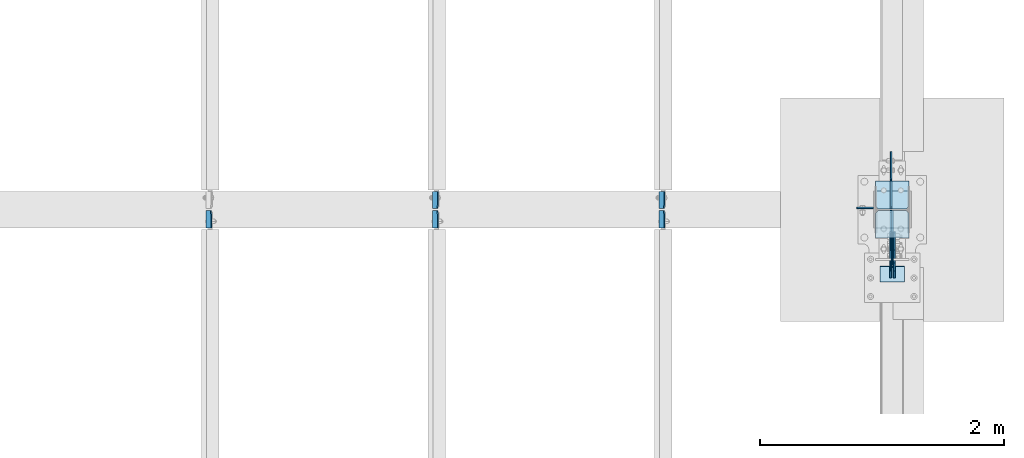
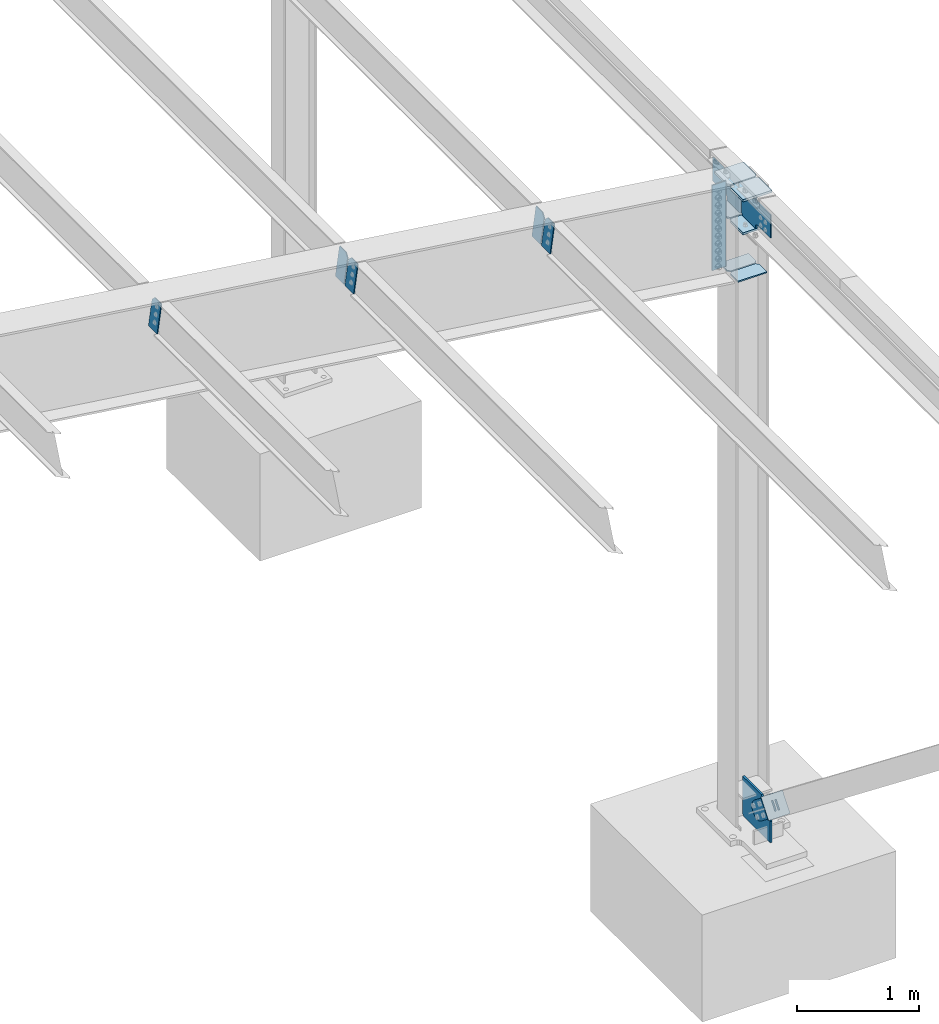
# One storey, part 1055 of 1179: 18 plates, 5 elements without a shape of their own.
"""IFC2X3 building model written with IfcOpenShell, lengths in millimetres."""

from ifc_helpers import new_model, si_unit, frame, origin_with_axes, place, context, subcontext, project, spatial, faceted_brep, material, type_object, element, aggregate, save


model = new_model("IFC2X3")

# Units and contexts
model_context = context("Model", 3, precision=1e-05, world=origin_with_axes())
body_context = subcontext(model_context, "Body", "Model", "MODEL_VIEW")
ifc_project = project(units=[si_unit("LENGTHUNIT", "METRE", prefix="MILLI"), si_unit("AREAUNIT", "SQUARE_METRE"), si_unit("VOLUMEUNIT", "CUBIC_METRE"), si_unit("MASSUNIT", "GRAM", prefix="KILO"), si_unit("TIMEUNIT", "SECOND"), si_unit("PLANEANGLEUNIT", "RADIAN"), si_unit("SOLIDANGLEUNIT", "STERADIAN"), si_unit("THERMODYNAMICTEMPERATUREUNIT", "DEGREE_CELSIUS"), si_unit("LUMINOUSINTENSITYUNIT", "LUMEN")], contexts=[model_context])

# Site, building, storey
site_placement = place(None, origin_with_axes())
site = spatial("IfcSite", under=ifc_project, at=site_placement, CompositionType="ELEMENT")
building_placement = place(site_placement, origin_with_axes())
building = spatial("IfcBuilding", under=site, at=building_placement, Name="Undefined", CompositionType="ELEMENT")
storey_placement = place(building_placement, origin_with_axes())
storey = spatial("IfcBuildingStorey", under=building, at=storey_placement, Name="Undefined", CompositionType="ELEMENT", Elevation=0.0)

# Assembly, plates
assembly_1_placement = place(storey_placement, origin_with_axes())
assembly_1 = element("IfcElementAssembly", 1, at=assembly_1_placement, inside=storey, Name="BEAM", AssemblyPlace="NOTDEFINED", PredefinedType="RIGID_FRAME")
ifc_material_1 = material(Name="STEEL/A36")
plate_type_1 = type_object("IfcPlateType", PredefinedType="NOTDEFINED")
plate_1_placement = place(assembly_1_placement, frame((36209.7723149352, 27058.9375, 6408.7167576418), z_axis=(0.0, 1.0, 0.0), x_axis=(-0.133813222971046, 0.0, -0.991006569785539)))
plate_1 = element("IfcPlate", 2, at=plate_1_placement, type_object=plate_type_1, material=ifc_material_1, Name="PLATE", context=body_context, shape_type="Brep", body=[
    faceted_brep([(0.0, -4.76250000000073, 34.9249999999993), (0.0, -4.76250000001164, 141.287499999999), (-3.63797880709171e-12, 4.76249999998981, 141.287499999999), (0.0, 4.76250000000073, 34.9249999999993), (290.512500000297, -4.76249999966967, 141.287499999999), (290.512500000294, 4.76250000033906, 141.287499999999), (290.512500000297, -4.76249999966967, 0.0), (290.512500000294, 4.76250000033906, 0.0), (34.9249992370715, -4.76249999996799, 0.0), (34.9249992370678, 4.76250000003347, 0.0)], [[[0, 1, 2, 3]], [[1, 4, 5, 2]], [[4, 6, 7, 5]], [[6, 8, 9, 7]], [[8, 0, 3, 9]], [[5, 7, 9, 3, 2]], [[8, 6, 4, 1, 0]]]),
])
plate_2_placement = place(assembly_1_placement, frame((34355.5723149357, 27058.9375, 6659.08490599859), z_axis=(0.0, 1.0, 0.0), x_axis=(-0.133813222971046, 0.0, -0.991006569785539)))
plate_2 = element("IfcPlate", 3, at=plate_2_placement, type_object=plate_type_1, material=ifc_material_1, Name="PLATE", context=body_context, shape_type="Brep", body=[
    faceted_brep([(0.0, -4.76250000000073, 34.9249999999993), (0.0, -4.76250000001164, 141.287499999999), (-3.63797880709171e-12, 4.76249999998981, 141.287499999999), (0.0, 4.76250000000073, 34.9249999999993), (290.512500000297, -4.76249999966967, 141.287499999999), (290.512500000294, 4.76250000033906, 141.287499999999), (290.512500000297, -4.76249999966967, 0.0), (290.512500000294, 4.76250000033906, 0.0), (34.9249992370715, -4.76249999996799, 0.0), (34.9249992370678, 4.76250000003347, 0.0)], [[[0, 1, 2, 3]], [[1, 4, 5, 2]], [[4, 6, 7, 5]], [[6, 8, 9, 7]], [[8, 0, 3, 9]], [[5, 7, 9, 3, 2]], [[8, 6, 4, 1, 0]]]),
])
plate_3_placement = place(assembly_1_placement, frame((36209.7723149411, 27043.0625, 6408.71675688842), z_axis=(0.0, -1.0, 0.0), x_axis=(-0.133813222971046, 0.0, -0.991006569785539)))
plate_3 = element("IfcPlate", 4, at=plate_3_placement, type_object=plate_type_1, material=ifc_material_1, Name="PLATE", context=body_context, shape_type="Brep", body=[
    faceted_brep([(0.0, -4.76250000000073, 34.9249999999993), (0.0, -4.76250000001164, 141.287499999999), (-3.63797880709171e-12, 4.76249999998981, 141.287499999999), (0.0, 4.76250000000073, 34.9249999999993), (290.512500000297, -4.76249999966967, 141.287499999999), (290.512500000294, 4.76250000033906, 141.287499999999), (290.512500000297, -4.76249999966967, 0.0), (290.512500000294, 4.76250000033906, 0.0), (34.9249992370715, -4.76249999996799, 0.0), (34.9249992370678, 4.76250000003347, 0.0)], [[[0, 1, 2, 3]], [[1, 4, 5, 2]], [[4, 6, 7, 5]], [[6, 8, 9, 7]], [[8, 0, 3, 9]], [[5, 7, 9, 3, 2]], [[8, 6, 4, 1, 0]]]),
])
plate_4_placement = place(assembly_1_placement, frame((34355.5723149415, 27043.0625, 6659.08490524521), z_axis=(0.0, -1.0, 0.0), x_axis=(-0.133813222971046, 0.0, -0.991006569785539)))
plate_4 = element("IfcPlate", 5, at=plate_4_placement, type_object=plate_type_1, material=ifc_material_1, Name="PLATE", context=body_context, shape_type="Brep", body=[
    faceted_brep([(0.0, -4.76250000000073, 34.9249999999993), (0.0, -4.76250000001164, 141.287499999999), (-3.63797880709171e-12, 4.76249999998981, 141.287499999999), (0.0, 4.76250000000073, 34.9249999999993), (290.512500000297, -4.76249999966967, 141.287499999999), (290.512500000294, 4.76250000033906, 141.287499999999), (290.512500000297, -4.76249999966967, 0.0), (290.512500000294, 4.76250000033906, 0.0), (34.9249992370715, -4.76249999996799, 0.0), (34.9249992370678, 4.76250000003347, 0.0)], [[[0, 1, 2, 3]], [[1, 4, 5, 2]], [[4, 6, 7, 5]], [[6, 8, 9, 7]], [[8, 0, 3, 9]], [[5, 7, 9, 3, 2]], [[8, 6, 4, 1, 0]]]),
])
plate_5_placement = place(assembly_1_placement, frame((32501.3723149418, 27043.0625, 6909.45305360179), z_axis=(0.0, -1.0, 0.0), x_axis=(-0.133813222971046, 0.0, -0.991006569785539)))
plate_5 = element("IfcPlate", 6, at=plate_5_placement, type_object=plate_type_1, material=ifc_material_1, Name="PLATE", context=body_context, shape_type="Brep", body=[
    faceted_brep([(0.0, -4.76250000000073, 34.9249999999993), (0.0, -4.76250000001164, 141.287499999999), (-3.63797880709171e-12, 4.76249999998981, 141.287499999999), (0.0, 4.76250000000073, 34.9249999999993), (290.512500000297, -4.76249999966967, 141.287499999999), (290.512500000294, 4.76250000033906, 141.287499999999), (290.512500000297, -4.76249999966967, 0.0), (290.512500000294, 4.76250000033906, 0.0), (34.9249992370715, -4.76249999996799, 0.0), (34.9249992370678, 4.76250000003347, 0.0)], [[[0, 1, 2, 3]], [[1, 4, 5, 2]], [[4, 6, 7, 5]], [[6, 8, 9, 7]], [[8, 0, 3, 9]], [[5, 7, 9, 3, 2]], [[8, 6, 4, 1, 0]]]),
])
aggregate(assembly_1, [plate_1, plate_2, plate_3, plate_4, plate_5])

# Assembly, plate
assembly_2_placement = place(storey_placement, origin_with_axes())
assembly_2 = element("IfcElementAssembly", 7, at=assembly_2_placement, inside=storey, Name="COLUMN", AssemblyPlace="NOTDEFINED", PredefinedType="RIGID_FRAME")
ifc_material_2 = material(Name="STEEL/A572-GR.50")
plate_type_2 = type_object("IfcPlateType", PredefinedType="NOTDEFINED")
plate_6_placement = place(assembly_2_placement, frame((38074.6, 27045.44375, -228.599999999999), z_axis=(0.0, 0.0, 1.0), x_axis=(0.0, -1.0, 0.0)))
plate_6 = element("IfcPlate", 8, at=plate_6_placement, type_object=plate_type_2, material=ifc_material_2, Name="PLATE", context=body_context, shape_type="Brep", body=[
    faceted_brep([(0.0, -9.52500000000146, 19.0499992370605), (0.0, -9.52500000000146, 393.418048976154), (0.0, 9.52500000000146, 393.418048976154), (0.0, 9.52500000000146, 19.0499992370605), (307.483903883029, -9.52500000000146, 393.418048976154), (307.483903883029, 9.52500000000146, 393.418048976154), (450.70235677221, -9.52500000000146, 211.18708185742), (450.70235677221, 9.52500000000146, 211.18708185742), (450.70235677221, -9.52500000000146, 0.0), (450.70235677221, 9.52500000000146, 0.0), (19.0499992370605, -9.52500000000146, 0.0), (19.0499992370605, 9.52500000000146, 0.0)], [[[0, 1, 2, 3]], [[1, 4, 5, 2]], [[4, 6, 7, 5]], [[6, 8, 9, 7]], [[8, 10, 11, 9]], [[10, 0, 3, 11]], [[5, 7, 9, 11, 3, 2]], [[10, 8, 6, 4, 1, 0]]]),
])

assembly_3_placement = place(storey_placement, origin_with_axes())
assembly_3 = element("IfcElementAssembly", 9, at=assembly_3_placement, inside=storey, AssemblyPlace="NOTDEFINED", PredefinedType="RIGID_FRAME")
plate_type_3 = type_object("IfcPlateType", PredefinedType="NOTDEFINED")
plate_7_placement = place(assembly_3_placement, frame((38058.725, 26549.8646879964, 223.501853368135), z_axis=(0.0, -0.61792019367569, -0.786240824587351), x_axis=(0.0, 0.786240824587352, -0.617920193675689)))
plate_7 = element("IfcPlate", 10, at=plate_7_placement, type_object=plate_type_3, material=ifc_material_1, context=body_context, shape_type="Brep", body=[
    faceted_brep([(0.0, -6.34999999999854, 0.0), (-8.18545231595635e-11, -6.34999999999854, 91.5986124346418), (-8.18545231595635e-11, 6.34999999999854, 91.5986124346418), (0.0, 6.34999999999854, 0.0), (82.5500000001266, -6.34999999999854, 91.5986124347546), (82.5500000001266, 6.34999999999854, 91.5986124347546), (184.150000000493, -6.34999999999854, 136.286806217293), (184.150000000493, 6.34999999999854, 136.286806217293), (329.234985848627, -6.34999999999854, 136.286806217511), (329.234985848627, 6.34999999999854, 136.286806217511), (363.86305410257, -6.34999999999854, 129.398855183379), (363.86305410257, 6.34999999999854, 129.398855183379), (393.219312869078, -6.34999999999854, 109.783630186394), (393.219312869078, 6.34999999999854, 109.783630186394), (412.8345378661, -6.34999999999854, 80.4273714198789), (412.8345378661, 6.34999999999854, 80.4273714198789), (419.72248890029, -6.34999999999854, 45.7993092699908), (419.72248890029, 6.34999999999854, 45.7993092699908), (412.834537866132, -6.34999999999854, 11.171241015978), (412.834537866132, 6.34999999999854, 11.171241015978), (393.219312869132, -6.34999999999854, -18.1850177505985), (393.219312869132, 6.34999999999854, -18.1850177505985), (363.863054102636, -6.34999999999854, -37.8002427476786), (363.863054102636, 6.34999999999854, -37.8002427476786), (329.234988900062, -6.34999999999854, -44.6881937819198), (329.234988900062, 6.34999999999854, -44.6881937819198), (184.150000000598, -6.34999999999854, -44.6881937821345), (184.150000000598, 6.34999999999854, -44.6881937821345), (82.550000000203, -6.34999999999854, 1.2732925824821e-10), (82.550000000203, 6.34999999999854, 1.2732925824821e-10)], [[[0, 1, 2, 3]], [[1, 4, 5, 2]], [[4, 6, 7, 5]], [[6, 8, 9, 7]], [[8, 10, 11, 9]], [[10, 12, 13, 11]], [[12, 14, 15, 13]], [[14, 16, 17, 15]], [[16, 18, 19, 17]], [[18, 20, 21, 19]], [[20, 22, 23, 21]], [[22, 24, 25, 23]], [[24, 26, 27, 25]], [[26, 28, 29, 27]], [[28, 0, 3, 29]], [[5, 7, 9, 11, 13, 15, 17, 19, 21, 23, 25, 27, 29, 3, 2]], [[28, 26, 24, 22, 20, 18, 16, 14, 12, 10, 8, 6, 4, 1, 0]]]),
])
aggregate(assembly_3, [plate_7])

assembly_4_placement = place(storey_placement, origin_with_axes())
assembly_4 = element("IfcElementAssembly", 11, at=assembly_4_placement, inside=storey, AssemblyPlace="NOTDEFINED", PredefinedType="RIGID_FRAME")
plate_8_placement = place(assembly_4_placement, frame((38090.475, 26549.8646879964, 223.501853368135), z_axis=(0.0, -0.61792019367569, -0.786240824587351), x_axis=(0.0, 0.786240824587352, -0.617920193675689)))
plate_8 = element("IfcPlate", 12, at=plate_8_placement, type_object=plate_type_3, material=ifc_material_1, context=body_context, shape_type="Brep", body=[
    faceted_brep([(0.0, -6.34999999999854, 0.0), (-8.18545231595635e-11, -6.34999999999854, 91.5986124346418), (-8.18545231595635e-11, 6.34999999999854, 91.5986124346418), (0.0, 6.34999999999854, 0.0), (82.5500000001266, -6.34999999999854, 91.5986124347546), (82.5500000001266, 6.34999999999854, 91.5986124347546), (184.150000000493, -6.34999999999854, 136.286806217293), (184.150000000493, 6.34999999999854, 136.286806217293), (329.234985848627, -6.34999999999854, 136.286806217511), (329.234985848627, 6.34999999999854, 136.286806217511), (363.86305410257, -6.34999999999854, 129.398855183379), (363.86305410257, 6.34999999999854, 129.398855183379), (393.219312869078, -6.34999999999854, 109.783630186394), (393.219312869078, 6.34999999999854, 109.783630186394), (412.8345378661, -6.34999999999854, 80.4273714198789), (412.8345378661, 6.34999999999854, 80.4273714198789), (419.72248890029, -6.34999999999854, 45.7993092699908), (419.72248890029, 6.34999999999854, 45.7993092699908), (412.834537866132, -6.34999999999854, 11.171241015978), (412.834537866132, 6.34999999999854, 11.171241015978), (393.219312869132, -6.34999999999854, -18.1850177505985), (393.219312869132, 6.34999999999854, -18.1850177505985), (363.863054102636, -6.34999999999854, -37.8002427476786), (363.863054102636, 6.34999999999854, -37.8002427476786), (329.234988900062, -6.34999999999854, -44.6881937819198), (329.234988900062, 6.34999999999854, -44.6881937819198), (184.150000000598, -6.34999999999854, -44.6881937821345), (184.150000000598, 6.34999999999854, -44.6881937821345), (82.550000000203, -6.34999999999854, 1.2732925824821e-10), (82.550000000203, 6.34999999999854, 1.2732925824821e-10)], [[[0, 1, 2, 3]], [[1, 4, 5, 2]], [[4, 6, 7, 5]], [[6, 8, 9, 7]], [[8, 10, 11, 9]], [[10, 12, 13, 11]], [[12, 14, 15, 13]], [[14, 16, 17, 15]], [[16, 18, 19, 17]], [[18, 20, 21, 19]], [[20, 22, 23, 21]], [[22, 24, 25, 23]], [[24, 26, 27, 25]], [[26, 28, 29, 27]], [[28, 0, 3, 29]], [[5, 7, 9, 11, 13, 15, 17, 19, 21, 23, 25, 27, 29, 3, 2]], [[28, 26, 24, 22, 20, 18, 16, 14, 12, 10, 8, 6, 4, 1, 0]]]),
])
aggregate(assembly_4, [plate_8])

assembly_5_placement = place(storey_placement, origin_with_axes())
assembly_5 = element("IfcElementAssembly", 13, at=assembly_5_placement, inside=storey, Name="Plate", AssemblyPlace="NOTDEFINED", PredefinedType="RIGID_FRAME")
plate_type_4 = type_object("IfcPlateType", PredefinedType="NOTDEFINED")
plate_9_placement = place(assembly_5_placement, frame((37973.0, 26461.2799947716, 105.648604689442), z_axis=(0.0, 0.617920193675691, 0.786240824587351), x_axis=(1.0, 0.0, 0.0)))
plate_9 = element("IfcPlate", 14, at=plate_9_placement, type_object=plate_type_4, material=ifc_material_1, Name="Plate", context=body_context, shape_type="Brep", body=[
    faceted_brep([(0.0, -3.17500000000109, 0.0), (0.0, -3.17500000000291, 203.200000000368), (0.0, 3.17499999998836, 203.200000000361), (0.0, 3.17500000000109, 7.27595761418343e-12), (203.199999999997, -3.17500000000291, 203.200000000368), (203.199999999997, 3.17499999998836, 203.200000000361), (203.199999999997, -3.17499999999927, 3.63797880709171e-12), (203.199999999997, 3.17499999999382, -3.63797880709171e-12)], [[[0, 1, 2, 3]], [[1, 4, 5, 2]], [[4, 6, 7, 5]], [[6, 0, 3, 7]], [[5, 7, 3, 2]], [[6, 4, 1, 0]]]),
])
aggregate(assembly_5, [plate_9])

# Plate
plate_type_5 = type_object("IfcPlateType", PredefinedType="NOTDEFINED")
plate_10_placement = place(assembly_2_placement, frame((38211.125, 27285.15625, 5756.275), z_axis=(-1.0, 0.0, 0.0), x_axis=(0.0, -1.0, 0.0)))
plate_10 = element("IfcPlate", 15, at=plate_10_placement, type_object=plate_type_5, material=ifc_material_2, Name="PLATE", context=body_context, shape_type="Brep", body=[
    faceted_brep([(0.0, -9.52499999999964, 0.0), (0.0, -9.52499999999964, 273.050000000003), (0.0, 9.52499999999964, 273.050000000003), (0.0, 9.52499999999964, 0.0), (206.374999618529, -9.52499999999964, 273.049999999996), (206.374999618529, 9.52499999999964, 273.049999999996), (228.599999999999, -9.52499999999964, 250.824999618526), (228.599999999999, 9.52499999999964, 250.824999618526), (228.599999999999, -9.52499999999964, 22.2250003814697), (228.599999999999, 9.52499999999964, 22.2250003814697), (206.374999618529, -9.52499999999964, 0.0), (206.374999618529, 9.52499999999964, 0.0)], [[[0, 1, 2, 3]], [[1, 4, 5, 2]], [[4, 6, 7, 5]], [[6, 8, 9, 7]], [[8, 10, 11, 9]], [[10, 0, 3, 11]], [[5, 7, 9, 11, 3, 2]], [[10, 8, 6, 4, 1, 0]]]),
])

plate_11_placement = place(assembly_2_placement, frame((38211.125, 27285.15625, 6086.475), z_axis=(-1.0, 0.0, 0.0), x_axis=(0.0, -1.0, 0.0)))
plate_11 = element("IfcPlate", 16, at=plate_11_placement, type_object=plate_type_5, material=ifc_material_2, Name="PLATE", context=body_context, shape_type="Brep", body=[
    faceted_brep([(0.0, -9.52499999999964, 0.0), (0.0, -9.52499999999964, 273.050000000003), (0.0, 9.52499999999964, 273.050000000003), (0.0, 9.52499999999964, 0.0), (206.374999618529, -9.52499999999964, 273.049999999996), (206.374999618529, 9.52499999999964, 273.049999999996), (228.599999999999, -9.52499999999964, 250.824999618526), (228.599999999999, 9.52499999999964, 250.824999618526), (228.599999999999, -9.52499999999964, 22.2250003814697), (228.599999999999, 9.52499999999964, 22.2250003814697), (206.374999618529, -9.52499999999964, 0.0), (206.374999618529, 9.52499999999964, 0.0)], [[[0, 1, 2, 3]], [[1, 4, 5, 2]], [[4, 6, 7, 5]], [[6, 8, 9, 7]], [[8, 10, 11, 9]], [[10, 0, 3, 11]], [[5, 7, 9, 11, 3, 2]], [[10, 8, 6, 4, 1, 0]]]),
])

plate_type_6 = type_object("IfcPlateType", PredefinedType="NOTDEFINED")
plate_12_placement = place(assembly_2_placement, frame((38064.28125, 27056.5484025688, 5784.85), z_axis=(0.0, 0.707106781186542, 0.707106781186553), x_axis=(0.0, 0.707106781186553, -0.707106781186542)))
plate_12 = element("IfcPlate", 17, at=plate_12_placement, type_object=plate_type_6, material=ifc_material_2, Name="PLATE", context=body_context, shape_type="Brep", body=[
    faceted_brep([(0.0, -6.34999999999854, 0.0), (-193.075506603058, -6.34999999999854, 193.075506603045), (-193.075506603058, 6.34999999999854, 193.075506603045), (0.0, 6.34999999999854, 0.0), (-193.075506603127, -6.34999999999854, 220.016274966196), (-193.075506603127, 6.34999999999854, 220.016274966196), (-45.4625466137659, -6.34999999999854, 367.629234955561), (-45.4625466137659, 6.34999999999854, 367.629234955561), (-40.9724182834834, -6.34999999999854, 363.139106625282), (-40.9724182834834, 6.34999999999854, 363.139106625282), (-32.7320653471797, -6.34999999999854, 357.633078824321), (-32.7320653471797, 6.34999999999854, 357.633078824321), (-23.0119063110942, -6.34999999999854, 355.699618979137), (-23.0119063110942, 6.34999999999854, 355.699618979137), (-13.2917472750196, -6.34999999999854, 357.633078824298), (-13.2917472750196, 6.34999999999854, 357.633078824298), (-5.05139433873046, -6.34999999999854, 363.139106625236), (-5.05139433873046, 6.34999999999854, 363.139106625236), (147.612959988404, -6.34999999999854, 515.803460952378), (147.612959988404, 6.34999999999854, 515.803460952378), (309.257570167709, -6.34999999999854, 354.158850773083), (309.257570167709, 6.34999999999854, 354.158850773083), (156.593215840574, -6.34999999999854, 201.494496445941), (156.593215840574, 6.34999999999854, 201.494496445941), (151.087188039633, -6.34999999999854, 193.254143509652), (151.087188039633, 6.34999999999854, 193.254143509652), (149.153728194477, -6.34999999999854, 183.533984473575), (149.153728194477, 6.34999999999854, 183.533984473575), (151.087188039659, -6.34999999999854, 173.813825437492), (151.087188039659, 6.34999999999854, 173.813825437492), (156.593215840621, -6.34999999999854, 165.573472501186), (156.593215840621, 6.34999999999854, 165.573472501186), (174.553728352508, -6.34999999999854, 147.612959989299), (174.553728352508, 6.34999999999854, 147.612959989299), (26.9407683631471, -6.34999999999854, -6.91215973347425e-11), (26.9407683631471, 6.34999999999854, -6.91215973347425e-11)], [[[0, 1, 2, 3]], [[1, 4, 5, 2]], [[4, 6, 7, 5]], [[6, 8, 9, 7]], [[8, 10, 11, 9]], [[10, 12, 13, 11]], [[12, 14, 15, 13]], [[14, 16, 17, 15]], [[16, 18, 19, 17]], [[18, 20, 21, 19]], [[20, 22, 23, 21]], [[22, 24, 25, 23]], [[24, 26, 27, 25]], [[26, 28, 29, 27]], [[28, 30, 31, 29]], [[30, 32, 33, 31]], [[32, 34, 35, 33]], [[34, 0, 3, 35]], [[5, 7, 9, 11, 13, 15, 17, 19, 21, 23, 25, 27, 29, 31, 33, 35, 3, 2]], [[34, 32, 30, 28, 26, 24, 22, 20, 18, 16, 14, 12, 10, 8, 6, 4, 1, 0]]]),
])

plate_type_7 = type_object("IfcPlateType", PredefinedType="NOTDEFINED")
plate_13_placement = place(assembly_2_placement, frame((37938.075, 26816.84375, 5754.6875), z_axis=(1.0, 0.0, 0.0), x_axis=(0.0, 1.0, 0.0)))
plate_13 = element("IfcPlate", 18, at=plate_13_placement, type_object=plate_type_7, material=ifc_material_2, Name="PLATE", context=body_context, shape_type="Brep", body=[
    faceted_brep([(0.0, -11.1125000000002, 0.0), (0.0, -11.1125000000002, 273.050000000003), (0.0, 11.1125000000002, 273.050000000003), (0.0, 11.1125000000002, 0.0), (206.374999618529, -11.1125000000002, 273.050000000003), (206.374999618529, 11.1125000000002, 273.050000000003), (228.599999999999, -11.1125000000002, 250.824999618533), (228.599999999999, 11.1125000000002, 250.824999618533), (228.599999999999, -11.1125000000002, 22.2250003814697), (228.599999999999, 11.1125000000002, 22.2250003814697), (206.374999618529, -11.1125000000002, 0.0), (206.374999618529, 11.1125000000002, 0.0)], [[[0, 1, 2, 3]], [[1, 4, 5, 2]], [[4, 6, 7, 5]], [[6, 8, 9, 7]], [[8, 10, 11, 9]], [[10, 0, 3, 11]], [[5, 7, 9, 11, 3, 2]], [[10, 8, 6, 4, 1, 0]]]),
])

plate_14_placement = place(assembly_2_placement, frame((37938.075, 26816.84375, 6084.8875), z_axis=(1.0, 0.0, 0.0), x_axis=(0.0, 1.0, 0.0)))
plate_14 = element("IfcPlate", 19, at=plate_14_placement, type_object=plate_type_7, material=ifc_material_2, Name="PLATE", context=body_context, shape_type="Brep", body=[
    faceted_brep([(0.0, -11.1125000000002, 0.0), (0.0, -11.1125000000002, 273.050000000003), (0.0, 11.1125000000002, 273.050000000003), (0.0, 11.1125000000002, 0.0), (206.374999618529, -11.1125000000002, 273.050000000003), (206.374999618529, 11.1125000000002, 273.050000000003), (228.599999999999, -11.1125000000002, 250.824999618533), (228.599999999999, 11.1125000000002, 250.824999618533), (228.599999999999, -11.1125000000002, 22.2250003814697), (228.599999999999, 11.1125000000002, 22.2250003814697), (206.374999618529, -11.1125000000002, 0.0), (206.374999618529, 11.1125000000002, 0.0)], [[[0, 1, 2, 3]], [[1, 4, 5, 2]], [[4, 6, 7, 5]], [[6, 8, 9, 7]], [[8, 10, 11, 9]], [[10, 0, 3, 11]], [[5, 7, 9, 11, 3, 2]], [[10, 8, 6, 4, 1, 0]]]),
])

plate_type_8 = type_object("IfcPlateType", PredefinedType="NOTDEFINED")
plate_15_placement = place(assembly_2_placement, frame((38063.4875, 27045.44375, 5784.85000339458), z_axis=(0.0, -0.707106781186506, 0.707106781186589), x_axis=(0.0, -0.70710678118659, -0.707106781186505)))
plate_15 = element("IfcPlate", 20, at=plate_15_placement, type_object=plate_type_8, material=ifc_material_2, Name="PLATE", context=body_context, shape_type="Brep", body=[
    faceted_brep([(0.0, -6.34999999999854, 0.0), (-190.8304439942, -6.34999999999854, 190.830441150882), (-190.8304439942, 6.34999999999854, 190.830441150882), (0.0, 6.34999999999854, 0.0), (-190.830443994197, -6.34999999999854, 217.771209313387), (-190.830443994197, 6.34999999999854, 217.771209313387), (-43.2174837074454, -6.34999999999854, 365.384167401086), (-43.2174837074454, 6.34999999999854, 365.384167401086), (-40.9724182834834, -6.34999999999854, 363.139106625282), (-40.9724182834834, 6.34999999999854, 363.139106625282), (-32.7320653471797, -6.34999999999854, 357.633078824321), (-32.7320653471797, 6.34999999999854, 357.633078824321), (-23.0119063110942, -6.34999999999854, 355.699618979137), (-23.0119063110942, 6.34999999999854, 355.699618979137), (-13.2917472750196, -6.34999999999854, 357.633078824298), (-13.2917472750196, 6.34999999999854, 357.633078824298), (-5.05139433873046, -6.34999999999854, 363.139106625236), (-5.05139433873046, 6.34999999999854, 363.139106625236), (147.612959988404, -6.34999999999854, 515.803460952378), (147.612959988404, 6.34999999999854, 515.803460952378), (309.257570167709, -6.34999999999854, 354.158850773083), (309.257570167709, 6.34999999999854, 354.158850773083), (156.593215840574, -6.34999999999854, 201.494496445941), (156.593215840574, 6.34999999999854, 201.494496445941), (151.087188039633, -6.34999999999854, 193.254143509652), (151.087188039633, 6.34999999999854, 193.254143509652), (149.153728194477, -6.34999999999854, 183.533984473575), (149.153728194477, 6.34999999999854, 183.533984473575), (151.087188039659, -6.34999999999854, 173.813825437492), (151.087188039659, 6.34999999999854, 173.813825437492), (156.593215840621, -6.34999999999854, 165.573472501186), (156.593215840621, 6.34999999999854, 165.573472501186), (174.553728352508, -6.34999999999854, 147.612959989299), (174.553728352508, 6.34999999999854, 147.612959989299), (26.9407683631471, -6.34999999999854, -6.91215973347425e-11), (26.9407683631471, 6.34999999999854, -6.91215973347425e-11)], [[[0, 1, 2, 3]], [[1, 4, 5, 2]], [[4, 6, 7, 5]], [[6, 8, 9, 7]], [[8, 10, 11, 9]], [[10, 12, 13, 11]], [[12, 14, 15, 13]], [[14, 16, 17, 15]], [[16, 18, 19, 17]], [[18, 20, 21, 19]], [[20, 22, 23, 21]], [[22, 24, 25, 23]], [[24, 26, 27, 25]], [[26, 28, 29, 27]], [[28, 30, 31, 29]], [[30, 32, 33, 31]], [[32, 34, 35, 33]], [[34, 0, 3, 35]], [[5, 7, 9, 11, 13, 15, 17, 19, 21, 23, 25, 27, 29, 31, 33, 35, 3, 2]], [[34, 32, 30, 28, 26, 24, 22, 20, 18, 16, 14, 12, 10, 8, 6, 4, 1, 0]]]),
])

plate_type_9 = type_object("IfcPlateType", PredefinedType="NOTDEFINED")
plate_16_placement = place(assembly_2_placement, frame((38211.125, 27045.44375, 5226.44326994722), z_axis=(-1.0, 0.0, 0.0), x_axis=(0.0, -1.0, 0.0)))
plate_16 = element("IfcPlate", 21, at=plate_16_placement, type_object=plate_type_9, material=ifc_material_1, Name="PLATE", context=body_context, shape_type="Brep", body=[
    faceted_brep([(0.0, -6.34999999999854, 22.2250003814697), (0.0, -6.35000000000036, 250.82499961853), (0.0, 6.35000000000036, 250.82499961853), (0.0, 6.34999999999854, 22.2250003814697), (22.2250003814697, -6.35000000000036, 273.05), (22.2250003814697, 6.35000000000036, 273.05), (146.050003051758, -6.35000000000036, 273.049987792969), (146.050003051758, 6.35000000000036, 273.049987792969), (146.050003051758, -6.35000000000036, 0.0), (146.050003051758, 6.35000000000036, 0.0), (22.2250003814697, -6.34999999999854, 0.0), (22.2250003814697, 6.34999999999854, 0.0)], [[[0, 1, 2, 3]], [[1, 4, 5, 2]], [[4, 6, 7, 5]], [[6, 8, 9, 7]], [[8, 10, 11, 9]], [[10, 0, 3, 11]], [[5, 7, 9, 11, 3, 2]], [[10, 8, 6, 4, 1, 0]]]),
])

plate_17_placement = place(assembly_2_placement, frame((38211.125, 27202.60625, 5226.44326994722), z_axis=(-1.0, 0.0, 0.0), x_axis=(0.0, -1.0, 0.0)))
plate_17 = element("IfcPlate", 22, at=plate_17_placement, type_object=plate_type_9, material=ifc_material_1, Name="PLATE", context=body_context, shape_type="Brep", body=[
    faceted_brep([(0.0, -6.34999999999854, 0.0), (0.0, -6.34999999999991, 273.05), (0.0, 6.34999999999991, 273.05), (0.0, 6.34999999999854, 0.0), (123.824999618599, -6.34999999999991, 273.05), (123.824999618599, 6.34999999999991, 273.05), (146.050000000068, -6.34999999999991, 250.82499961853), (146.050000000068, 6.34999999999991, 250.82499961853), (146.050000000068, -6.34999999999991, 22.2250003814697), (146.050000000068, 6.34999999999991, 22.2250003814697), (123.824999618599, -6.34999999999991, 0.0), (123.824999618599, 6.34999999999991, 0.0)], [[[0, 1, 2, 3]], [[1, 4, 5, 2]], [[4, 6, 7, 5]], [[6, 8, 9, 7]], [[8, 10, 11, 9]], [[10, 0, 3, 11]], [[5, 7, 9, 11, 3, 2]], [[10, 8, 6, 4, 1, 0]]]),
])

plate_type_10 = type_object("IfcPlateType", PredefinedType="NOTDEFINED")
plate_18_placement = place(assembly_2_placement, frame((37919.025, 27065.2875, 6144.07423301968), z_axis=(-1.0, 0.0, 0.0), x_axis=(0.0, 0.0, -1.0)))
plate_18 = element("IfcPlate", 23, at=plate_18_placement, type_object=plate_type_10, material=ifc_material_1, Name="PLATE", context=body_context, shape_type="Brep", body=[
    faceted_brep([(0.0, -6.34999999999854, 0.0), (0.0, -6.34999999999854, 133.350000000002), (0.0, 6.34999999999854, 133.350000000002), (0.0, 6.34999999999854, 0.0), (850.900024414062, -6.34999999999854, 133.350006103516), (850.900024414062, 6.34999999999854, 133.350006103516), (850.900024414062, -6.34999999999854, 0.0), (850.900024414062, 6.34999999999854, 0.0)], [[[0, 1, 2, 3]], [[1, 4, 5, 2]], [[4, 6, 7, 5]], [[6, 0, 3, 7]], [[5, 7, 3, 2]], [[6, 4, 1, 0]]]),
])

aggregate(assembly_2, [plate_6, plate_13, plate_14, plate_15, plate_10, plate_11, plate_12, plate_16, plate_17, plate_18])

save(model, "model.ifc")
